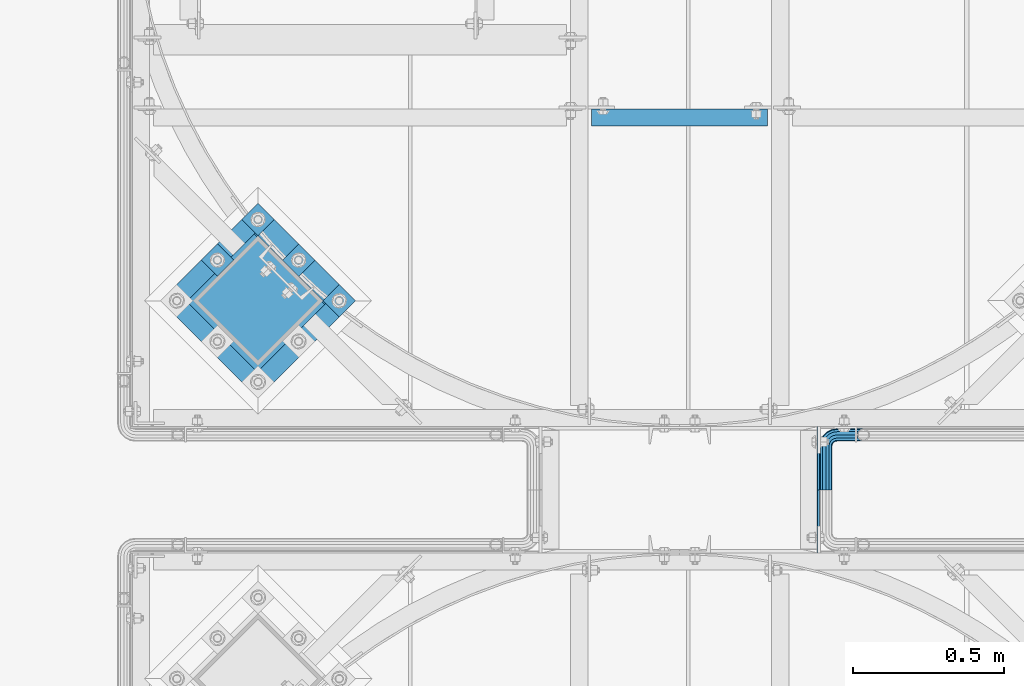
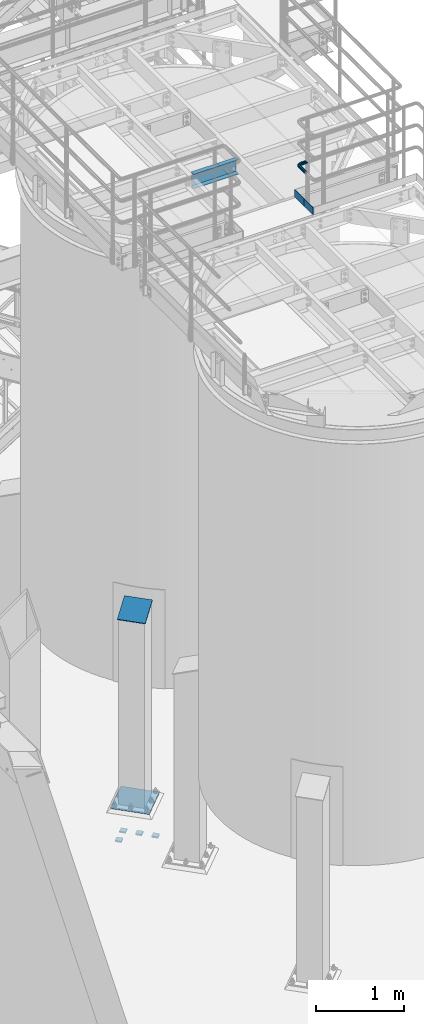
# One storey, part 1115 of 1876: 9 beams, 1 member, 5 elements without a shape of their own.
"""IFC2X3 building model written with IfcOpenShell, lengths in millimetres."""

from ifc_helpers import new_model, si_unit, frame, origin_with_axes, place, context, subcontext, project, spatial, faceted_brep, material, type_object, element, aggregate, save


model = new_model("IFC2X3")

# Units and contexts
model_context = context("Model", 3, precision=1e-05, world=origin_with_axes())
body_context = subcontext(model_context, "Body", "Model", "MODEL_VIEW")
ifc_project = project(units=[si_unit("LENGTHUNIT", "METRE", prefix="MILLI"), si_unit("AREAUNIT", "SQUARE_METRE"), si_unit("VOLUMEUNIT", "CUBIC_METRE"), si_unit("MASSUNIT", "GRAM", prefix="KILO"), si_unit("TIMEUNIT", "SECOND"), si_unit("PLANEANGLEUNIT", "RADIAN"), si_unit("SOLIDANGLEUNIT", "STERADIAN"), si_unit("THERMODYNAMICTEMPERATUREUNIT", "DEGREE_CELSIUS"), si_unit("LUMINOUSINTENSITYUNIT", "LUMEN")], contexts=[model_context])

# Site, building, storey
site_placement = place(None, origin_with_axes())
site = spatial("IfcSite", under=ifc_project, at=site_placement, CompositionType="ELEMENT")
building_placement = place(site_placement, origin_with_axes())
building = spatial("IfcBuilding", under=site, at=building_placement, Name="Undefined", CompositionType="ELEMENT")
storey_placement = place(building_placement, origin_with_axes())
storey = spatial("IfcBuildingStorey", under=building, at=storey_placement, Name="Undefined", CompositionType="ELEMENT", Elevation=0.0)

# Assembly, beams
assembly_1_placement = place(storey_placement, origin_with_axes())
assembly_1 = element("IfcElementAssembly", 1, at=assembly_1_placement, inside=storey, Name="HANDRAIL", AssemblyPlace="NOTDEFINED", PredefinedType="RIGID_FRAME")
ifc_material_1 = material()
beam_type_1 = type_object("IfcBeamType", Name="PIPE1-1/4STD", PredefinedType="NOTDEFINED")
beam_1_placement = place(assembly_1_placement, frame((5666.23343150122, -11563.31485742, 8480.425), z_axis=(0.0, 0.0, -1.0), x_axis=(0.0, 1.0, 0.0)))
beam_1 = element("IfcBeam", 2, at=beam_1_placement, type_object=beam_type_1, material=ifc_material_1, Name="HANDRAIL", ObjectType="PIPE1-1/4STD", context=body_context, shape_type="Brep", body=[
    faceted_brep([(192.588302246095, 106.710451704997, 18.2575475625836), (192.588309811317, 106.710451704997, 13.3999536615011), (190.810302246095, 106.234036013759, 15.1779612267255), (182.047302246094, 103.88599926758, 17.5259999999998), (182.047302246094, 103.88599926758, 21.0820000000003), (173.284302246095, 106.23404006795, 15.1779612267255), (171.506309811319, 106.710451704997, 13.3999687919495), (171.506302246094, 106.710451704997, 18.2575475625836), (163.78975468351, 114.42699926758, 10.5409999999993), (163.78975468351, 114.42699926758, -10.5409999999993), (160.965302246093, 124.968002319336, 0.0), (166.869341019368, 111.347420496947, 8.76300000000083), (164.521302246094, 113.69545927022, 0.0), (166.869341019368, 111.347420496947, -8.76300000000083), (171.506309811319, 106.710451704997, -13.3999687919495), (171.506302246094, 106.710451704997, -18.2575475625836), (182.047302246094, 103.88599926758, -17.5259999999998), (182.047302246094, 103.88599926758, -21.0820000000003), (173.284302246095, 106.23404006795, -15.1779612267255), (192.588309811317, 106.710451704997, -13.3999536615011), (192.588302246095, 106.710451704997, -18.2575475625836), (190.810302246095, 106.234036013759, -15.1779612267255), (203.129309811318, 124.96799926758, 0.0), (200.304849808677, 114.42699926758, -10.5409999999993), (200.304849808677, 114.42699926758, 10.5409999999993), (197.225263472819, 111.347405366499, -8.76300000000083), (199.573302246094, 113.695444139772, 0.0), (197.225263472819, 111.347405366499, 8.76300000000083), (0.0, -18.2575475625836, -10.5409999999993), (0.0, -10.5410000000002, -18.2575475625836), (143.947303771973, -10.5409999999983, -18.2575475625836), (143.947303771973, -18.2575475625817, -10.5409999999993), (-4.28826751885936e-09, 0.0, -21.0820000000003), (143.947303771973, 1.81898940354586e-12, -21.0820000000003), (0.0, 10.5410000000002, -18.2575475625836), (143.947303771973, 10.5410000000011, -18.2575475625836), (0.0, 18.2575475625836, -10.5409999999993), (143.947303771973, 18.2575475625854, -10.5409999999993), (9.09494701772928e-13, 21.0820000000003, 0.0), (143.947303771973, 21.0820000000012, 0.0), (0.0, 18.2575475625836, 10.5409999999993), (143.947303771973, 18.2575475625854, 10.5409999999993), (0.0, 10.5410000000002, 18.2575475625836), (143.947303771973, 10.5410000000011, 18.2575475625836), (0.0, 0.0, 21.0820000000003), (143.947303771973, 1.81898940354586e-12, 21.0820000000003), (0.0, -10.5410000000002, 18.2575475625836), (143.947303771973, -10.5409999999983, 18.2575475625836), (0.0, -18.2575475625836, 10.5409999999993), (143.947303771973, -18.2575475625817, 10.5409999999993), (9.09494701772928e-13, -21.0820000000003, 0.0), (143.947303771973, -21.0819999999985, 0.0), (162.235547061553, -18.1854268220586, 0.0), (161.362743258587, -15.4992129264883, 10.5409999999993), (158.978198923845, -8.16034008379211, 18.2575475625836), (155.720850786138, 1.86474665447531, 21.0820000000003), (152.463502648432, 11.8898333927418, 18.2575475625836), (150.07895831369, 19.228706235438, 10.5409999999993), (149.206154510724, 21.9149201310092, 0.0), (150.07895831369, 19.2287062354389, -10.5409999999993), (152.463502648432, 11.8898333927418, -18.2575475625836), (155.720850786138, 1.86474665447531, -21.0820000000003), (158.978198923845, -8.16034008379211, -18.2575475625836), (161.362743258587, -15.4992129264883, -10.5409999999993), (163.789754683512, 38.0999984741229, -10.5409999999993), (160.965302246095, 38.0999984741229, 0.0), (163.789754683512, 38.0999984741229, 10.5409999999993), (171.506302246096, 38.0999984741229, 18.2575475625836), (182.047302246096, 38.099998474122, 21.0820000000003), (192.588302246097, 38.099998474122, 18.2575475625836), (200.304849808679, 38.099998474122, 10.5409999999993), (203.129302246094, 38.0999984741229, 0.0), (182.047302246096, 38.099998474122, -21.0820000000003), (171.506302246096, 38.0999984741229, -18.2575475625836), (192.588302246095, 38.099998474122, -18.2575475625836), (200.304849808679, 38.099998474122, -10.5409999999993), (162.818596010658, 31.9683439324062, -10.5409999999993), (170.157468853355, 29.5837995976653, -18.2575475625836), (160.132382115087, 32.841147735372, 0.0), (162.818596010658, 31.9683439324062, 10.5409999999993), (170.157468853355, 29.5837995976653, 18.2575475625836), (180.182555591622, 26.3264514599587, 21.0820000000003), (190.207642329889, 23.069103322252, 18.2575475625836), (197.546515172586, 20.6845589875102, 10.5409999999993), (200.232729068157, 19.8117551845444, 0.0), (197.546515172586, 20.6845589875102, -10.5409999999993), (190.207642329889, 23.069103322252, -18.2575475625836), (180.182555591622, 26.3264514599587, -21.0820000000003), (166.243001885488, 21.9012256030801, -18.2575475625836), (174.770850023195, 15.7053812586637, -21.0820000000003), (160.000183769456, 26.436898458981, -10.5409999999993), (157.715153747784, 28.0970699474965, 0.0), (160.000183769456, 26.436898458981, 10.5409999999993), (166.243001885488, 21.9012256030801, 18.2575475625836), (174.770850023195, 15.7053812586637, 21.0820000000003), (183.298698160899, 9.50953691424729, 18.2575475625836), (189.541516276931, 4.97386405834641, 10.5409999999993), (191.826546298606, 3.31369256983089, 0.0), (189.541516276931, 4.97386405834641, -10.5409999999993), (183.298698160899, 9.50953691424729, -18.2575475625836), (166.341920987434, 7.27645222290266, -21.0820000000003), (172.53776533185, -1.25139591480183, -18.2575475625836), (160.146076643017, 15.8043003606081, -18.2575475625836), (155.610403787116, 22.0471184766402, -10.5409999999993), (153.950232298601, 24.3321484983135, 0.0), (155.610403787116, 22.0471184766402, 10.5409999999993), (160.146076643017, 15.8043003606081, 18.2575475625836), (166.341920987434, 7.27645222290266, 21.0820000000003), (172.53776533185, -1.25139591480183, 18.2575475625836), (177.07343818775, -7.49421403083397, 10.5409999999993), (178.733609676266, -9.77924405250724, 0.0), (177.07343818775, -7.49421403083397, -10.5409999999993), (0.0, -15.1779612267264, -8.76300000000083), (0.0, -8.76299999999992, -15.1779612267255), (0.0, 0.0, -17.5259999999998), (0.0, 8.76299999999992, -15.1779612267255), (0.0, 15.1779612267264, -8.76300000000083), (0.0, 17.5259999999998, 0.0), (0.0, 15.1779612267264, 8.76300000000083), (0.0, 8.76299999999992, 15.1779612267255), (0.0, 0.0, 17.5259999999998), (0.0, -8.76299999999992, 15.1779612267255), (0.0, -15.1779612267264, 8.76300000000083), (0.0, -17.5259999999998, 0.0), (143.947303771973, -8.7629999999981, 15.1779612267255), (143.947303771973, -15.1779612267246, 8.76300000000083), (143.947303771973, -17.5259999999989, 0.0), (143.947303771973, -15.1779612267246, -8.76300000000083), (143.947303771973, -8.76299999999901, -15.1779612267255), (143.947303771973, 1.81898940354586e-12, -17.5259999999998), (143.947303771973, 8.76300000000174, -15.1779612267255), (143.947303771973, 15.1779612267273, -8.76300000000083), (143.947303771973, 17.5260000000017, 0.0), (143.947303771973, 15.1779612267273, 8.76300000000083), (143.947303771973, 8.76300000000174, 15.1779612267255), (143.947303771973, 1.81898940354586e-12, 17.5259999999998), (155.720850786138, 1.86474665447531, 17.5259999999998), (158.428766707846, -6.46936159781944, 15.1779612267255), (160.411098745162, -12.5703522742779, 8.76300000000083), (161.136682629554, -14.8034698501133, 0.0), (160.411098745162, -12.5703522742779, -8.76300000000083), (158.428766707846, -6.46936159781944, -15.1779612267255), (155.720850786138, 1.86474665447531, -17.5259999999998), (153.01293486443, 10.1988549067692, -15.1779612267255), (151.030602827115, 16.2998455832276, -8.76300000000083), (150.305018942723, 18.5329631590639, 0.0), (151.030602827115, 16.2998455832276, 8.76300000000083), (153.01293486443, 10.1988549067692, 15.1779612267255), (161.191158821593, 14.3658681446095, 15.1779612267255), (166.341920987434, 7.27645222290266, 17.5259999999998), (157.420539218494, 19.5556807952871, 8.76300000000083), (156.040396655753, 21.4552840663164, 0.0), (157.420539218494, 19.5556807952871, -8.76300000000083), (161.191158821593, 14.3658681446095, -15.1779612267255), (166.341920987434, 7.27645222290266, -17.5259999999998), (171.492683153274, 0.187036301196713, -15.1779612267255), (175.263302756372, -5.00277634948088, -8.76300000000083), (176.643445319114, -6.90237962051015, 0.0), (175.263302756372, -5.00277634948088, 8.76300000000083), (171.492683153274, 0.187036301196713, 15.1779612267255), (174.770850023195, 15.7053812586637, 17.5259999999998), (181.860265944901, 10.5546190928235, 15.1779612267255), (167.681434101487, 20.8561434245039, 15.1779612267255), (162.49162145081, 24.6267630276025, 8.76300000000083), (160.592018179781, 26.0069055903441, 0.0), (162.49162145081, 24.6267630276025, -8.76300000000083), (167.681434101487, 20.8561434245039, -15.1779612267255), (174.770850023195, 15.7053812586637, -17.5259999999998), (181.860265944901, 10.5546190928235, -15.1779612267255), (187.050078595577, 6.78399948972492, -8.76300000000083), (188.949681866608, 5.40385692698328, 0.0), (187.050078595577, 6.78399948972492, 8.76300000000083), (188.516663843917, 23.6185355382504, 15.1779612267255), (194.617654520374, 21.6362035009352, 8.76300000000083), (180.182555591622, 26.3264514599587, 17.5259999999998), (171.848447339327, 29.0343673816669, 15.1779612267255), (165.74745666287, 31.0166994189813, 8.76300000000083), (163.514339087033, 31.7422833033743, 0.0), (165.74745666287, 31.0166994189813, -8.76300000000083), (171.848447339327, 29.0343673816669, -15.1779612267255), (180.182555591622, 26.3264514599587, -17.5259999999998), (188.516663843917, 23.6185355382504, -15.1779612267255), (194.617654520374, 21.6362035009352, -8.76300000000083), (196.850772096212, 20.9106196165421, 0.0), (197.225263472821, 38.099998474122, 8.76300000000083), (199.573302246094, 38.0999984741229, 0.0), (190.810302246096, 38.099998474122, 15.1779612267255), (182.047302246096, 38.099998474122, 17.5259999999998), (173.284302246095, 38.099998474122, 15.1779612267255), (166.86934101937, 38.0999984741229, 8.76300000000083), (164.521302246096, 38.0999984741229, 0.0), (166.86934101937, 38.0999984741229, -8.76300000000083), (173.284302246095, 38.099998474122, -15.1779612267255), (182.047302246096, 38.099998474122, -17.5259999999998), (190.810302246096, 38.099998474122, -15.1779612267255), (197.225263472821, 38.099998474122, -8.76300000000083)], [[[0, 1, 2, 3, 4]], [[4, 3, 5, 6, 7]], [[8, 9, 10]], [[7, 6, 11, 12, 13, 14, 15, 9, 8]], [[16, 17, 15, 14, 18]], [[19, 20, 17, 16, 21]], [[22, 23, 24]], [[24, 23, 20, 19, 25, 26, 27, 1, 0]], [[28, 29, 30, 31]], [[29, 32, 33, 30]], [[32, 34, 35, 33]], [[34, 36, 37, 35]], [[36, 38, 39, 37]], [[38, 40, 41, 39]], [[40, 42, 43, 41]], [[42, 44, 45, 43]], [[44, 46, 47, 45]], [[46, 48, 49, 47]], [[48, 50, 51, 49]], [[49, 51, 52, 53]], [[47, 49, 53, 54]], [[45, 47, 54, 55]], [[43, 45, 55, 56]], [[41, 43, 56, 57]], [[39, 41, 57, 58]], [[37, 39, 58, 59]], [[35, 37, 59, 60]], [[33, 35, 60, 61]], [[30, 33, 61, 62]], [[31, 30, 62, 63]], [[64, 65, 10, 9]], [[65, 66, 8, 10]], [[66, 67, 7, 8]], [[67, 68, 4, 7]], [[68, 69, 0, 4]], [[69, 70, 24, 0]], [[70, 71, 22, 24]], [[72, 73, 15, 17]], [[74, 72, 17, 20]], [[75, 74, 20, 23]], [[71, 75, 23, 22]], [[73, 64, 9, 15]], [[76, 64, 73, 77]], [[78, 65, 64, 76]], [[79, 66, 65, 78]], [[80, 67, 66, 79]], [[81, 68, 67, 80]], [[82, 69, 68, 81]], [[83, 70, 69, 82]], [[84, 71, 70, 83]], [[85, 75, 71, 84]], [[86, 74, 75, 85]], [[87, 72, 74, 86]], [[77, 73, 72, 87]], [[88, 77, 87, 89]], [[90, 76, 77, 88]], [[91, 78, 76, 90]], [[92, 79, 78, 91]], [[93, 80, 79, 92]], [[94, 81, 80, 93]], [[95, 82, 81, 94]], [[96, 83, 82, 95]], [[97, 84, 83, 96]], [[98, 85, 84, 97]], [[99, 86, 85, 98]], [[89, 87, 86, 99]], [[100, 89, 99, 101]], [[102, 88, 89, 100]], [[103, 90, 88, 102]], [[104, 91, 90, 103]], [[105, 92, 91, 104]], [[106, 93, 92, 105]], [[107, 94, 93, 106]], [[108, 95, 94, 107]], [[109, 96, 95, 108]], [[110, 97, 96, 109]], [[111, 98, 97, 110]], [[101, 99, 98, 111]], [[62, 101, 111, 63]], [[61, 100, 101, 62]], [[60, 102, 100, 61]], [[59, 103, 102, 60]], [[58, 104, 103, 59]], [[57, 105, 104, 58]], [[56, 106, 105, 57]], [[55, 107, 106, 56]], [[54, 108, 107, 55]], [[53, 109, 108, 54]], [[52, 110, 109, 53]], [[63, 111, 110, 52]], [[51, 31, 63, 52]], [[50, 28, 31, 51]], [[48, 46, 44, 42, 40, 38, 36, 34, 32, 29, 28, 50], [112, 113, 114, 115, 116, 117, 118, 119, 120, 121, 122, 123]], [[122, 121, 124, 125]], [[123, 122, 125, 126]], [[112, 123, 126, 127]], [[113, 112, 127, 128]], [[114, 113, 128, 129]], [[115, 114, 129, 130]], [[116, 115, 130, 131]], [[117, 116, 131, 132]], [[118, 117, 132, 133]], [[119, 118, 133, 134]], [[120, 119, 134, 135]], [[121, 120, 135, 124]], [[124, 135, 136, 137]], [[125, 124, 137, 138]], [[126, 125, 138, 139]], [[127, 126, 139, 140]], [[128, 127, 140, 141]], [[129, 128, 141, 142]], [[130, 129, 142, 143]], [[131, 130, 143, 144]], [[132, 131, 144, 145]], [[133, 132, 145, 146]], [[134, 133, 146, 147]], [[135, 134, 147, 136]], [[147, 148, 149, 136]], [[146, 150, 148, 147]], [[145, 151, 150, 146]], [[144, 152, 151, 145]], [[143, 153, 152, 144]], [[142, 154, 153, 143]], [[141, 155, 154, 142]], [[140, 156, 155, 141]], [[139, 157, 156, 140]], [[138, 158, 157, 139]], [[137, 159, 158, 138]], [[136, 149, 159, 137]], [[149, 160, 161, 159]], [[148, 162, 160, 149]], [[150, 163, 162, 148]], [[151, 164, 163, 150]], [[152, 165, 164, 151]], [[153, 166, 165, 152]], [[154, 167, 166, 153]], [[155, 168, 167, 154]], [[156, 169, 168, 155]], [[157, 170, 169, 156]], [[158, 171, 170, 157]], [[159, 161, 171, 158]], [[161, 172, 173, 171]], [[160, 174, 172, 161]], [[162, 175, 174, 160]], [[163, 176, 175, 162]], [[164, 177, 176, 163]], [[165, 178, 177, 164]], [[166, 179, 178, 165]], [[167, 180, 179, 166]], [[168, 181, 180, 167]], [[169, 182, 181, 168]], [[170, 183, 182, 169]], [[171, 173, 183, 170]], [[173, 184, 185, 183]], [[172, 186, 184, 173]], [[174, 187, 186, 172]], [[175, 188, 187, 174]], [[176, 189, 188, 175]], [[177, 190, 189, 176]], [[178, 191, 190, 177]], [[179, 192, 191, 178]], [[180, 193, 192, 179]], [[181, 194, 193, 180]], [[182, 195, 194, 181]], [[183, 185, 195, 182]], [[195, 185, 26, 25]], [[21, 194, 195, 25, 19]], [[193, 194, 21, 16]], [[192, 193, 16, 18]], [[13, 191, 192, 18, 14]], [[190, 191, 13, 12]], [[189, 190, 12, 11]], [[188, 189, 11, 6, 5]], [[187, 188, 5, 3]], [[186, 187, 3, 2]], [[184, 186, 2, 1, 27]], [[185, 184, 27, 26]]]),
])
ifc_material_2 = material(Name="STEEL/A36")
beam_type_2 = type_object("IfcBeamType", PredefinedType="NOTDEFINED")
beam_2_placement = place(assembly_1_placement, frame((5641.97643150122, -11563.31485742, 8080.375), z_axis=(0.0, 0.0, 1.0), x_axis=(0.0, 1.0, 0.0)))
beam_2 = element("IfcBeam", 3, at=beam_2_placement, type_object=beam_type_2, material=ifc_material_2, Name="PLATE", context=body_context, shape_type="Brep", body=[
    faceted_brep([(0.0, 3.17500000000018, -50.8000000000002), (0.0, 3.17500000000018, 50.8000000000002), (209.550048827514, 3.17500000000018, 50.8000000000002), (209.550048827514, 3.17500000000018, -50.8000000000002), (0.0, -3.17500000000018, 50.8000000000002), (209.550048827514, -3.17500000000018, 50.8000000000002), (0.0, -3.17500000000018, -50.8000000000002), (209.550048827514, -3.17500000000018, -50.8000000000002)], [[[0, 1, 2, 3]], [[1, 4, 5, 2]], [[4, 6, 7, 5]], [[6, 0, 3, 7]], [[5, 7, 3, 2]], [[6, 4, 1, 0]]]),
])
aggregate(assembly_1, [beam_2, beam_1])

# Assembly, beam
assembly_2_placement = place(storey_placement, origin_with_axes())
assembly_2 = element("IfcElementAssembly", 4, at=assembly_2_placement, inside=storey, Name="HANDRAIL", AssemblyPlace="NOTDEFINED", PredefinedType="RIGID_FRAME")
beam_3_placement = place(assembly_2_placement, frame((5641.97643150122, -11772.8649062475, 8080.375), z_axis=(0.0, 0.0, 1.0), x_axis=(0.0, 1.0, 0.0)))
beam_3 = element("IfcBeam", 5, at=beam_3_placement, type_object=beam_type_2, material=ifc_material_2, Name="PLATE", context=body_context, shape_type="Brep", body=[
    faceted_brep([(0.0, 3.17500000000018, -50.8000000000002), (0.0, 3.17500000000018, 50.8000000000002), (209.550048827514, 3.17500000000018, 50.8000000000002), (209.550048827514, 3.17500000000018, -50.8000000000002), (0.0, -3.17500000000018, 50.8000000000002), (209.550048827514, -3.17500000000018, 50.8000000000002), (0.0, -3.17500000000018, -50.8000000000002), (209.550048827514, -3.17500000000018, -50.8000000000002)], [[[0, 1, 2, 3]], [[1, 4, 5, 2]], [[4, 6, 7, 5]], [[6, 0, 3, 7]], [[5, 7, 3, 2]], [[6, 4, 1, 0]]]),
])
aggregate(assembly_2, [beam_3])

assembly_3_placement = place(storey_placement, origin_with_axes())
assembly_3 = element("IfcElementAssembly", 6, at=assembly_3_placement, inside=storey, Name="BEAM", AssemblyPlace="NOTDEFINED", PredefinedType="RIGID_FRAME")
beam_type_3 = type_object("IfcBeamType", Name="C8X11.5", PredefinedType="NOTDEFINED")
beam_4_placement = place(assembly_3_placement, frame((4876.80333884985, -10328.2393554687, 7896.225), z_axis=(0.0, 0.0, 1.0), x_axis=(1.0, 0.0, 0.0)))
beam_4 = element("IfcBeam", 7, at=beam_4_placement, type_object=beam_type_3, material=ifc_material_2, Name="BEAM", ObjectType="C8X11.5", context=body_context, shape_type="Brep", body=[
    faceted_brep([(12.7000000000007, 28.5749999999998, -101.6), (12.7000000000007, 28.5749999999998, 101.6), (596.900000000001, 28.5750000000007, 101.6), (596.900000000001, 28.5750000000007, -101.6), (12.7000000000007, -28.5749999999998, 101.6), (596.900000000001, -28.5750000000007, 101.6), (12.7000000000007, -28.5749999999998, 96.8355949999996), (596.900000000001, -28.5750000000007, 96.8355949999996), (12.7000000000007, 22.2250000000004, 88.3723149999996), (596.900000000001, 22.2250000000004, 88.3723149999996), (12.7000000000007, 22.2250000000004, -88.3723149999996), (596.900000000001, 22.2250000000004, -88.3723149999996), (12.7000000000007, -28.5749999999998, -96.8355949999996), (596.900000000001, -28.5750000000007, -96.8355949999996), (12.7000000000007, -28.5749999999998, -101.6), (596.900000000001, -28.5750000000007, -101.6)], [[[0, 1, 2, 3]], [[1, 4, 5, 2]], [[4, 6, 7, 5]], [[6, 8, 9, 7]], [[8, 10, 11, 9]], [[10, 12, 13, 11]], [[12, 14, 15, 13]], [[14, 0, 3, 15]], [[5, 7, 9, 11, 13, 15, 3, 2]], [[14, 12, 10, 8, 6, 4, 1, 0]]]),
])
aggregate(assembly_3, [beam_4])

# Assembly, member
assembly_4_placement = place(storey_placement, origin_with_axes())
assembly_4 = element("IfcElementAssembly", 8, at=assembly_4_placement, inside=storey, Name="COLUMN", AssemblyPlace="NOTDEFINED", PredefinedType="RIGID_FRAME")
member_type = type_object("IfcMemberType", PredefinedType="NOTDEFINED")
member_placement = place(assembly_4_placement, frame((3889.152847734, -10830.150466726, 2749.16704824061), z_axis=(-0.707106781186548, 0.707106781186547, 0.0), x_axis=(-0.664463024761458, -0.664463024761456, -0.342020141877215)))
member = element("IfcMember", 9, at=member_placement, type_object=member_type, material=ifc_material_2, Name="PLATE", context=body_context, shape_type="Brep", body=[
    faceted_brep([(0.0, 6.35000000000042, -165.100000000026), (0.0, 6.35000000000042, 165.100000000029), (337.061384869998, 6.34999999999997, 165.099999999921), (337.061384869996, 6.34999999999997, -165.100000000135), (1.81898940354586e-12, -6.34999999999849, 165.100000000029), (337.061384869998, -6.3499999999994, 165.099999999921), (0.0, -6.34999999999894, -165.100000000026), (337.061384869998, -6.3499999999994, -165.100000000136)], [[[0, 1, 2, 3]], [[1, 4, 5, 2]], [[4, 6, 7, 5]], [[6, 0, 3, 7]], [[5, 7, 3, 2]], [[6, 4, 1, 0]]]),
])
aggregate(assembly_4, [member])

# Assembly, beams
assembly_5_placement = place(storey_placement, origin_with_axes())
assembly_5 = element("IfcElementAssembly", 10, at=assembly_5_placement, inside=storey, Name="TEMPLATE", AssemblyPlace="NOTDEFINED", PredefinedType="RIGID_FRAME")
beam_type_4 = type_object("IfcBeamType", PredefinedType="NOTDEFINED")
beam_5_placement = place(assembly_5_placement, frame((4079.27394050429, -10909.4370575646, -542.925), z_axis=(-0.707106781186548, 0.707106781186547, 0.0), x_axis=(-0.707106781186547, -0.707106781186548, 0.0)))
beam_5 = element("IfcBeam", 11, at=beam_5_placement, type_object=beam_type_4, material=ifc_material_2, Name="PLATE", context=body_context, shape_type="Brep", body=[
    faceted_brep([(0.0, 9.52499999999998, -38.1000000000058), (-9.09494701772928e-13, 9.52499999999998, 38.1000000000076), (76.2000000000762, 9.52499999999998, 38.1000000000058), (76.2000000000762, 9.52499999999998, -38.1000000000058), (-9.09494701772928e-13, -9.52499999999998, 38.1000000000076), (76.2000000000762, -9.52499999999998, 38.1000000000058), (0.0, -9.52499999999998, -38.1000000000058), (76.2000000000762, -9.52499999999998, -38.1000000000058)], [[[0, 1, 2, 3]], [[1, 4, 5, 2]], [[4, 6, 7, 5]], [[6, 0, 3, 7]], [[5, 7, 3, 2]], [[6, 4, 1, 0]]]),
])
beam_6_placement = place(assembly_5_placement, frame((3944.57009868814, -10774.7332157485, -542.925), z_axis=(-0.707106781186548, 0.707106781186547, 0.0), x_axis=(-0.707106781186547, -0.707106781186548, 0.0)))
beam_6 = element("IfcBeam", 12, at=beam_6_placement, type_object=beam_type_4, material=ifc_material_2, Name="PLATE", context=body_context, shape_type="Brep", body=[
    faceted_brep([(0.0, 9.52499999999998, -38.1000000000058), (-9.09494701772928e-13, 9.52499999999998, 38.1000000000076), (76.2000000000762, 9.52499999999998, 38.1000000000058), (76.2000000000762, 9.52499999999998, -38.1000000000058), (-9.09494701772928e-13, -9.52499999999998, 38.1000000000076), (76.2000000000762, -9.52499999999998, 38.1000000000058), (0.0, -9.52499999999998, -38.1000000000058), (76.2000000000762, -9.52499999999998, -38.1000000000058)], [[[0, 1, 2, 3]], [[1, 4, 5, 2]], [[4, 6, 7, 5]], [[6, 0, 3, 7]], [[5, 7, 3, 2]], [[6, 4, 1, 0]]]),
])
beam_7_placement = place(assembly_5_placement, frame((3809.86625687198, -10640.0293739323, -542.925), z_axis=(-0.707106781186548, 0.707106781186547, 0.0), x_axis=(-0.707106781186547, -0.707106781186548, 0.0)))
beam_7 = element("IfcBeam", 13, at=beam_7_placement, type_object=beam_type_4, material=ifc_material_2, Name="PLATE", context=body_context, shape_type="Brep", body=[
    faceted_brep([(0.0, 9.52499999999998, -38.1000000000058), (-9.09494701772928e-13, 9.52499999999998, 38.1000000000076), (76.2000000000762, 9.52499999999998, 38.1000000000058), (76.2000000000762, 9.52499999999998, -38.1000000000058), (-9.09494701772928e-13, -9.52499999999998, 38.1000000000076), (76.2000000000762, -9.52499999999998, 38.1000000000058), (0.0, -9.52499999999998, -38.1000000000058), (76.2000000000762, -9.52499999999998, -38.1000000000058)], [[[0, 1, 2, 3]], [[1, 4, 5, 2]], [[4, 6, 7, 5]], [[6, 0, 3, 7]], [[5, 7, 3, 2]], [[6, 4, 1, 0]]]),
])
beam_8_placement = place(assembly_5_placement, frame((3675.16241505583, -10774.7332157485, -542.925), z_axis=(-0.707106781186548, 0.707106781186547, 0.0), x_axis=(-0.707106781186547, -0.707106781186548, 0.0)))
beam_8 = element("IfcBeam", 14, at=beam_8_placement, type_object=beam_type_4, material=ifc_material_2, Name="PLATE", context=body_context, shape_type="Brep", body=[
    faceted_brep([(0.0, 9.52499999999998, -38.1000000000058), (-9.09494701772928e-13, 9.52499999999998, 38.1000000000076), (76.2000000000762, 9.52499999999998, 38.1000000000058), (76.2000000000762, 9.52499999999998, -38.1000000000058), (-9.09494701772928e-13, -9.52499999999998, 38.1000000000076), (76.2000000000762, -9.52499999999998, 38.1000000000058), (0.0, -9.52499999999998, -38.1000000000058), (76.2000000000762, -9.52499999999998, -38.1000000000058)], [[[0, 1, 2, 3]], [[1, 4, 5, 2]], [[4, 6, 7, 5]], [[6, 0, 3, 7]], [[5, 7, 3, 2]], [[6, 4, 1, 0]]]),
])
beam_type_5 = type_object("IfcBeamType", PredefinedType="NOTDEFINED")
beam_9_placement = place(assembly_5_placement, frame((3944.570098688, -10774.7332157484, 40.4815), z_axis=(0.707106781186547, -0.707106781186548, 0.0), x_axis=(-0.707106781186547, -0.707106781186548, 0.0)))
beam_9 = element("IfcBeam", 15, at=beam_9_placement, type_object=beam_type_5, material=ifc_material_2, Name="TEMPLATE", context=body_context, shape_type="Brep", body=[
    faceted_brep([(9.09494701772928e-13, 2.3815, -228.600000000035), (-9.09494701772928e-13, 2.3815, 228.60000000004), (457.200000000363, 2.3815, 228.60000000004), (457.200000000362, 2.3815, -228.600000000037), (-9.09494701772928e-13, -2.3815, 228.60000000004), (457.200000000363, -2.3815, 228.60000000004), (9.09494701772928e-13, -2.3815, -228.600000000035), (457.200000000362, -2.3815, -228.600000000037)], [[[0, 1, 2, 3]], [[1, 4, 5, 2]], [[4, 6, 7, 5]], [[6, 0, 3, 7]], [[5, 7, 3, 2]], [[6, 4, 1, 0]]]),
])
aggregate(assembly_5, [beam_5, beam_6, beam_7, beam_8, beam_9])

save(model, "model.ifc")
